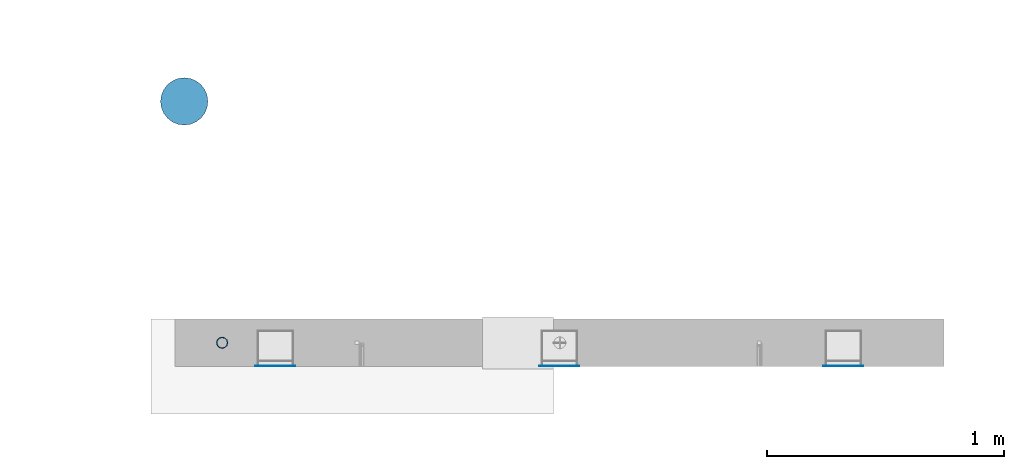
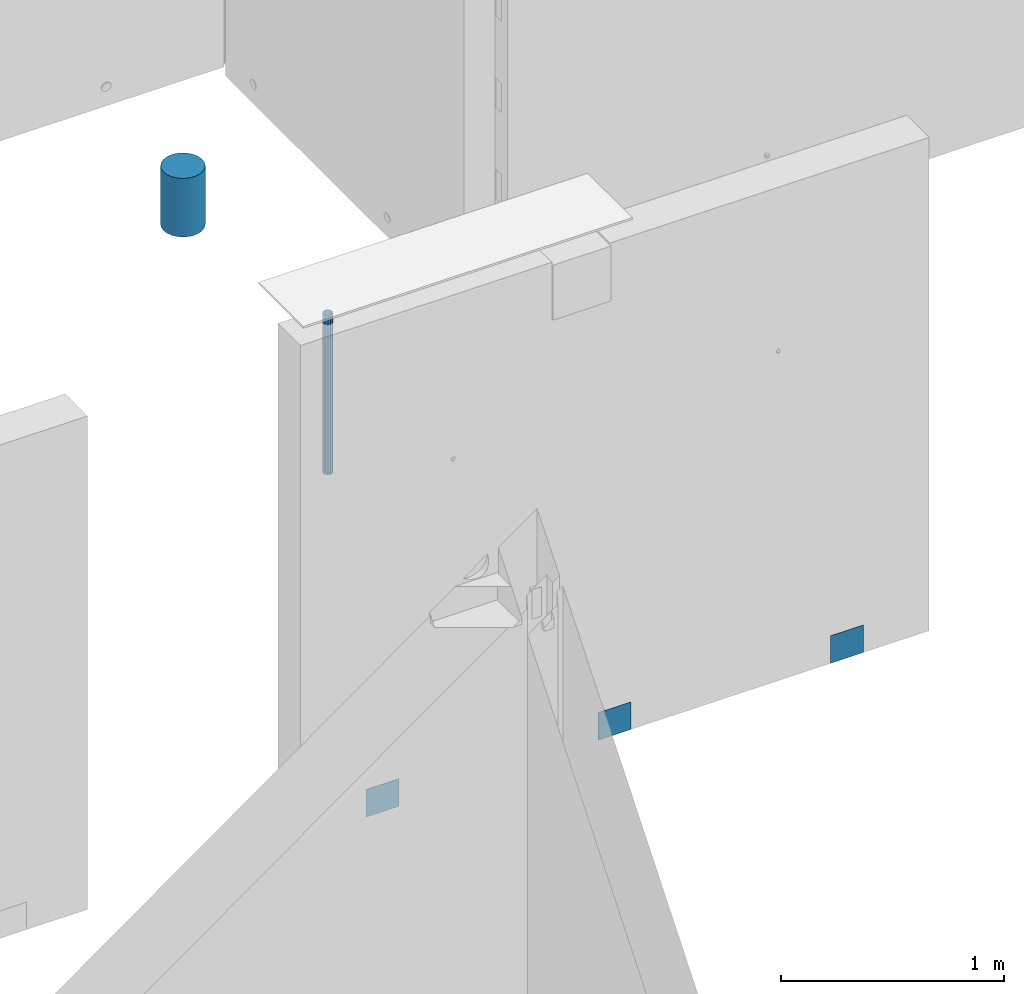
# One storey, part 18 of 264: 5 columns, 5 elements without a shape of their own.
"""IFC2X3 building model written with IfcOpenShell, lengths in millimetres."""

from ifc_helpers import new_model, si_unit, frame, origin_with_axes, place, context, subcontext, project, spatial, faceted_brep, material, type_object, element, aggregate, save


model = new_model("IFC2X3")

# Units and contexts
model_context = context("Model", 3, precision=1e-05, world=origin_with_axes())
body_context = subcontext(model_context, "Body", "Model", "MODEL_VIEW")
ifc_project = project(units=[si_unit("LENGTHUNIT", "METRE", prefix="MILLI"), si_unit("AREAUNIT", "SQUARE_METRE"), si_unit("VOLUMEUNIT", "CUBIC_METRE"), si_unit("MASSUNIT", "GRAM", prefix="KILO"), si_unit("TIMEUNIT", "SECOND"), si_unit("PLANEANGLEUNIT", "RADIAN"), si_unit("SOLIDANGLEUNIT", "STERADIAN"), si_unit("THERMODYNAMICTEMPERATUREUNIT", "DEGREE_CELSIUS"), si_unit("LUMINOUSINTENSITYUNIT", "LUMEN")], contexts=[model_context])

# Site, building, storey
site_placement = place(None, origin_with_axes())
site = spatial("IfcSite", under=ifc_project, at=site_placement, CompositionType="ELEMENT")
building_placement = place(site_placement, origin_with_axes())
building = spatial("IfcBuilding", under=site, at=building_placement, CompositionType="ELEMENT")
storey_placement = place(building_placement, origin_with_axes())
storey = spatial("IfcBuildingStorey", under=building, at=storey_placement, Name="K", CompositionType="ELEMENT", Elevation=0.0)

# Assemblies, columns
assembly_1_placement = place(storey_placement, origin_with_axes())
assembly_1 = element("IfcElementAssembly", 1, at=assembly_1_placement, inside=storey, AssemblyPlace="NOTDEFINED", PredefinedType="REINFORCEMENT_UNIT")
assembly_2_placement = place(assembly_1_placement, origin_with_axes())
assembly_2 = element("IfcElementAssembly", 2, at=assembly_2_placement, Name="Steel Assembly", AssemblyPlace="NOTDEFINED", PredefinedType="NOTDEFINED")
ifc_material_1 = material(Name="Undefined")
column_type_1 = type_object("IfcColumnType", PredefinedType="NOTDEFINED")
column_1_placement = place(assembly_2_placement, frame((28835.0003214753, 16881.0002441656, 78775.0000050936), z_axis=(0.0, -1.0, 0.0), x_axis=(0.0, 0.0, 1.0)))
column_1 = element("IfcColumn", 3, at=column_1_placement, type_object=column_type_1, material=ifc_material_1, Name="SPK3", context=body_context, shape_type="Brep", body=[
    faceted_brep([(0.0, 85.0, -1.0), (0.0, 85.0, 1.0), (150.0, 85.0, 1.0), (150.0, 85.0, -1.0), (0.0, -85.0, 1.0), (150.0, -85.0, 1.0), (0.0, -85.0, -1.0), (150.0, -85.0, -1.0)], [[[0, 1, 2, 3]], [[1, 4, 5, 2]], [[4, 6, 7, 5]], [[6, 0, 3, 7]], [[5, 7, 3, 2]], [[6, 4, 1, 0]]]),
])
aggregate(assembly_2, [column_1])
assembly_3_placement = place(assembly_1_placement, origin_with_axes())
assembly_3 = element("IfcElementAssembly", 4, at=assembly_3_placement, Name="Steel Assembly", AssemblyPlace="NOTDEFINED", PredefinedType="NOTDEFINED")
column_2_placement = place(assembly_3_placement, frame((30035.0003214753, 16881.0002441656, 78775.0000050936), z_axis=(0.0, -1.0, 0.0), x_axis=(0.0, 0.0, 1.0)))
column_2 = element("IfcColumn", 5, at=column_2_placement, type_object=column_type_1, material=ifc_material_1, Name="SPK3", context=body_context, shape_type="Brep", body=[
    faceted_brep([(0.0, 85.0, -1.0), (0.0, 85.0, 1.0), (150.0, 85.0, 1.0), (150.0, 85.0, -1.0), (0.0, -85.0, 1.0), (150.0, -85.0, 1.0), (0.0, -85.0, -1.0), (150.0, -85.0, -1.0)], [[[0, 1, 2, 3]], [[1, 4, 5, 2]], [[4, 6, 7, 5]], [[6, 0, 3, 7]], [[5, 7, 3, 2]], [[6, 4, 1, 0]]]),
])
aggregate(assembly_3, [column_2])
assembly_4_placement = place(assembly_1_placement, origin_with_axes())
assembly_4 = element("IfcElementAssembly", 6, at=assembly_4_placement, Name="Steel Assembly", AssemblyPlace="NOTDEFINED", PredefinedType="NOTDEFINED")
column_3_placement = place(assembly_4_placement, frame((31235.0003214753, 16881.0002441656, 78775.0000050936), z_axis=(0.0, -1.0, 0.0), x_axis=(0.0, 0.0, 1.0)))
column_3 = element("IfcColumn", 7, at=column_3_placement, type_object=column_type_1, material=ifc_material_1, Name="SPK3", context=body_context, shape_type="Brep", body=[
    faceted_brep([(0.0, 85.0, -1.0), (0.0, 85.0, 1.0), (150.0, 85.0, 1.0), (150.0, 85.0, -1.0), (0.0, -85.0, 1.0), (150.0, -85.0, 1.0), (0.0, -85.0, -1.0), (150.0, -85.0, -1.0)], [[[0, 1, 2, 3]], [[1, 4, 5, 2]], [[4, 6, 7, 5]], [[6, 0, 3, 7]], [[5, 7, 3, 2]], [[6, 4, 1, 0]]]),
])
aggregate(assembly_4, [column_3])
ifc_material_2 = material()
column_type_2 = type_object("IfcColumnType", Name="48.3X2.6", PredefinedType="NOTDEFINED")
column_4_placement = place(assembly_1_placement, frame((28609.9991042544, 16980.0, 80650.0), z_axis=(-1.0, 3.00000001838171e-08, 0.0), x_axis=(0.0, 0.0, 1.0)))
column_4 = element("IfcColumn", 8, at=column_4_placement, type_object=column_type_2, material=ifc_material_2, ObjectType="48.3X2.6", context=body_context, shape_type="Brep", body=[
    faceted_brep([(0.0, -21.5499999999993, 0.0), (0.0, -18.6628474515564, 10.7750000000015), (870.0, -18.6628474515564, 10.7750000000015), (870.0, -21.5499999999993, 0.0), (0.0, -10.7750000000015, 18.6628474515564), (870.0, -10.7750000000015, 18.6628474515564), (0.0, 0.0, 21.5499999999993), (870.0, 0.0, 21.5499999999993), (0.0, 10.7750000000015, 18.6628474515564), (870.0, 10.7750000000015, 18.6628474515564), (0.0, 18.6628474515564, 10.7750000000015), (870.0, 18.6628474515564, 10.7750000000015), (0.0, 21.5499999999993, 0.0), (870.0, 21.5499999999993, 0.0), (0.0, 18.6628474515564, -10.7750000000015), (870.0, 18.6628474515564, -10.7750000000015), (0.0, 10.7750000000015, -18.6628474515564), (870.0, 10.7750000000015, -18.6628474515564), (0.0, 0.0, -21.5499999999993), (870.0, 0.0, -21.5499999999993), (0.0, -10.7750000000015, -18.6628474515564), (870.0, -10.7750000000015, -18.6628474515564), (0.0, -18.6628474515564, -10.7750000000015), (870.0, -18.6628474515564, -10.7750000000015), (0.0, -24.1500000000015, 0.0), (0.0, -20.9145135013932, -12.0750000000007), (870.0, -20.9145135013932, -12.0750000000007), (870.0, -24.1500000000015, 0.0), (0.0, -12.0750000000007, -20.9145135013932), (870.0, -12.0750000000007, -20.9145135013932), (0.0, 0.0, -24.1500000000015), (870.0, 0.0, -24.1500000000015), (0.0, 12.0750000000007, -20.9145135013932), (870.0, 12.0750000000007, -20.9145135013932), (0.0, 20.9145135013932, -12.0750000000007), (870.0, 20.9145135013932, -12.0750000000007), (0.0, 24.1500000000015, 0.0), (870.0, 24.1500000000015, 0.0), (0.0, 20.9145135013932, 12.0750000000007), (870.0, 20.9145135013932, 12.0750000000007), (0.0, 12.0750000000007, 20.9145135013932), (870.0, 12.0750000000007, 20.9145135013932), (0.0, 0.0, 24.1500000000015), (870.0, 0.0, 24.1500000000015), (0.0, -12.0750000000007, 20.9145135013932), (870.0, -12.0750000000007, 20.9145135013932), (0.0, -20.9145135013932, 12.0750000000007), (870.0, -20.9145135013932, 12.0750000000007)], [[[0, 1, 2, 3]], [[1, 4, 5, 2]], [[4, 6, 7, 5]], [[6, 8, 9, 7]], [[8, 10, 11, 9]], [[10, 12, 13, 11]], [[12, 14, 15, 13]], [[14, 16, 17, 15]], [[16, 18, 19, 17]], [[18, 20, 21, 19]], [[20, 22, 23, 21]], [[22, 0, 3, 23]], [[24, 25, 26, 27]], [[25, 28, 29, 26]], [[28, 30, 31, 29]], [[30, 32, 33, 31]], [[32, 34, 35, 33]], [[34, 36, 37, 35]], [[36, 38, 39, 37]], [[38, 40, 41, 39]], [[40, 42, 43, 41]], [[42, 44, 45, 43]], [[44, 46, 47, 45]], [[46, 24, 27, 47]], [[29, 31, 33, 35, 37, 39, 41, 43, 45, 47, 27, 26], [5, 7, 9, 11, 13, 15, 17, 19, 21, 23, 3, 2]], [[46, 44, 42, 40, 38, 36, 34, 32, 30, 28, 25, 24], [22, 20, 18, 16, 14, 12, 10, 8, 6, 4, 1, 0]]]),
])
aggregate(assembly_1, [assembly_2, assembly_3, assembly_4, column_4])

# Assembly, column
assembly_5_placement = place(storey_placement, origin_with_axes())
assembly_5 = element("IfcElementAssembly", 9, at=assembly_5_placement, inside=storey, Name="Steel Assembly", AssemblyPlace="NOTDEFINED", PredefinedType="NOTDEFINED")
ifc_material_3 = material()
column_type_3 = type_object("IfcColumnType", Name="D200", PredefinedType="NOTDEFINED")
column_5_placement = place(assembly_5_placement, frame((28449.9996170402, 17999.9992355704, 81440.0), z_axis=(0.0, 1.0, 0.0), x_axis=(0.0, 0.0, 1.0)))
column_5 = element("IfcColumn", 10, at=column_5_placement, type_object=column_type_3, material=ifc_material_3, ObjectType="D200", context=body_context, shape_type="Brep", body=[
    faceted_brep([(0.0, -100.0, 0.0), (0.0, -96.5925826289022, -25.8819045102518), (320.0, -96.5925826289058, -25.8819045102518), (320.0, -100.0, 0.0), (0.0, -86.6025403784442, -50.0), (320.0, -86.6025403784442, -50.0), (0.0, -70.7106781186594, -70.710678118654), (320.0, -70.7106781186558, -70.710678118654), (0.0, -50.0, -86.6025403784442), (320.0, -50.0, -86.6025403784442), (0.0, -25.8819045102573, -96.5925826289076), (320.0, -25.8819045102537, -96.5925826289076), (0.0, 0.0, -100.0), (320.0, 0.0, -100.0), (0.0, 25.8819045102573, -96.5925826289076), (320.0, 25.8819045102537, -96.5925826289076), (0.0, 50.0, -86.6025403784442), (320.0, 50.0, -86.6025403784442), (0.0, 70.7106781186594, -70.710678118654), (320.0, 70.7106781186558, -70.710678118654), (0.0, 86.6025403784442, -50.0), (320.0, 86.6025403784442, -50.0), (0.0, 96.5925826289022, -25.8819045102518), (320.0, 96.5925826289058, -25.8819045102518), (0.0, 100.0, 0.0), (320.0, 100.0, 0.0), (0.0, 96.5925826289022, 25.8819045102518), (320.0, 96.5925826289058, 25.8819045102518), (0.0, 86.6025403784442, 50.0), (320.0, 86.6025403784442, 50.0), (0.0, 70.7106781186594, 70.710678118654), (320.0, 70.7106781186558, 70.710678118654), (0.0, 50.0, 86.6025403784442), (320.0, 50.0, 86.6025403784442), (0.0, 25.8819045102573, 96.5925826289076), (320.0, 25.8819045102537, 96.5925826289076), (0.0, 0.0, 100.0), (320.0, 0.0, 100.0), (0.0, -25.8819045102573, 96.5925826289076), (320.0, -25.8819045102537, 96.5925826289076), (0.0, -50.0, 86.6025403784442), (320.0, -50.0, 86.6025403784442), (0.0, -70.7106781186594, 70.710678118654), (320.0, -70.7106781186558, 70.710678118654), (0.0, -86.6025403784442, 50.0), (320.0, -86.6025403784442, 50.0), (0.0, -96.5925826289022, 25.8819045102518), (320.0, -96.5925826289058, 25.8819045102518)], [[[0, 1, 2, 3]], [[1, 4, 5, 2]], [[4, 6, 7, 5]], [[6, 8, 9, 7]], [[8, 10, 11, 9]], [[10, 12, 13, 11]], [[12, 14, 15, 13]], [[14, 16, 17, 15]], [[16, 18, 19, 17]], [[18, 20, 21, 19]], [[20, 22, 23, 21]], [[22, 24, 25, 23]], [[24, 26, 27, 25]], [[26, 28, 29, 27]], [[28, 30, 31, 29]], [[30, 32, 33, 31]], [[32, 34, 35, 33]], [[34, 36, 37, 35]], [[36, 38, 39, 37]], [[38, 40, 41, 39]], [[40, 42, 43, 41]], [[42, 44, 45, 43]], [[44, 46, 47, 45]], [[46, 0, 3, 47]], [[5, 7, 9, 11, 13, 15, 17, 19, 21, 23, 25, 27, 29, 31, 33, 35, 37, 39, 41, 43, 45, 47, 3, 2]], [[46, 44, 42, 40, 38, 36, 34, 32, 30, 28, 26, 24, 22, 20, 18, 16, 14, 12, 10, 8, 6, 4, 1, 0]]]),
])
aggregate(assembly_5, [column_5])

save(model, "model.ifc")
